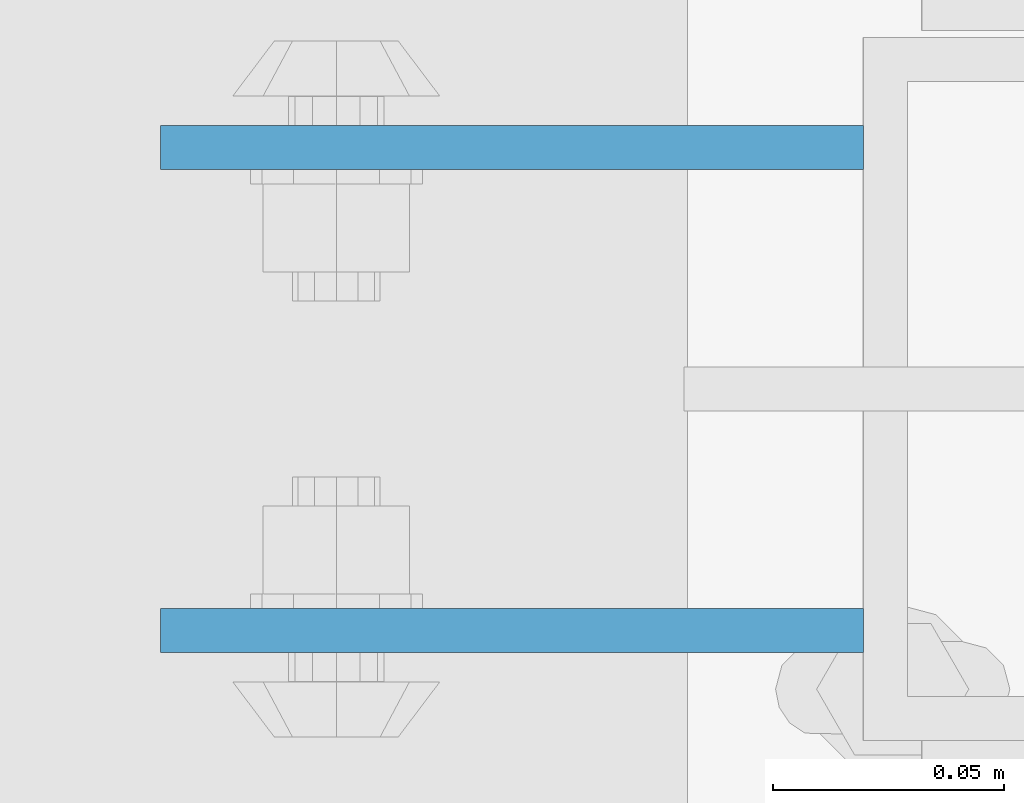
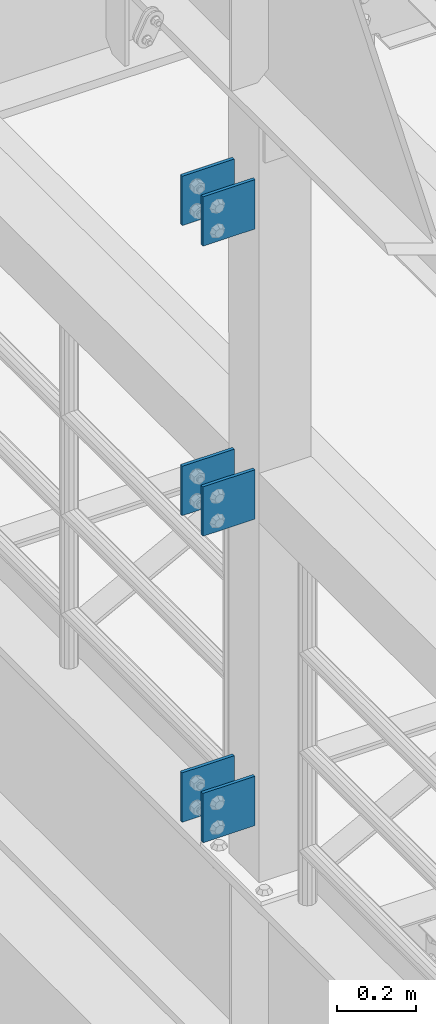
# One storey, part 1249 of 1876: 6 beams, 1 element without a shape of its own.
"""IFC2X3 building model written with IfcOpenShell, lengths in millimetres."""

from ifc_helpers import new_model, si_unit, frame, origin_with_axes, place, context, subcontext, project, spatial, faceted_brep, material, type_object, element, aggregate, save


model = new_model("IFC2X3")

# Units and contexts
model_context = context("Model", 3, precision=1e-05, world=origin_with_axes())
body_context = subcontext(model_context, "Body", "Model", "MODEL_VIEW")
ifc_project = project(units=[si_unit("LENGTHUNIT", "METRE", prefix="MILLI"), si_unit("AREAUNIT", "SQUARE_METRE"), si_unit("VOLUMEUNIT", "CUBIC_METRE"), si_unit("MASSUNIT", "GRAM", prefix="KILO"), si_unit("TIMEUNIT", "SECOND"), si_unit("PLANEANGLEUNIT", "RADIAN"), si_unit("SOLIDANGLEUNIT", "STERADIAN"), si_unit("THERMODYNAMICTEMPERATUREUNIT", "DEGREE_CELSIUS"), si_unit("LUMINOUSINTENSITYUNIT", "LUMEN")], contexts=[model_context])

# Site, building, storey
site_placement = place(None, origin_with_axes())
site = spatial("IfcSite", under=ifc_project, at=site_placement, CompositionType="ELEMENT")
building_placement = place(site_placement, origin_with_axes())
building = spatial("IfcBuilding", under=site, at=building_placement, Name="Undefined", CompositionType="ELEMENT")
storey_placement = place(building_placement, origin_with_axes())
storey = spatial("IfcBuildingStorey", under=building, at=storey_placement, Name="Undefined", CompositionType="ELEMENT", Elevation=0.0)

# Assembly, beams
assembly_placement = place(storey_placement, origin_with_axes())
assembly = element("IfcElementAssembly", 1, at=assembly_placement, inside=storey, Name="BEAM", AssemblyPlace="NOTDEFINED", PredefinedType="RIGID_FRAME")
ifc_material = material(Name="STEEL/A36")
beam_type = type_object("IfcBeamType", PredefinedType="NOTDEFINED")
beam_1_placement = place(assembly_placement, frame((-76.2, 3608.3875, 6330.95), z_axis=(0.0, 0.0, -1.0), x_axis=(-1.0, 0.0, 0.0)))
beam_1 = element("IfcBeam", 2, at=beam_1_placement, type_object=beam_type, material=ifc_material, Name="PLATE", context=body_context, shape_type="Brep", body=[
    faceted_brep([(0.0, 4.76249999999982, -76.1999999999998), (3.63797880709171e-12, 4.76249999999982, 76.1999969482422), (152.399993896484, 4.76250000000073, 76.1999969482422), (152.4, 4.76249999999982, -76.1999999999998), (3.63797880709171e-12, -4.76249999999982, 76.1999969482422), (152.399993896484, -4.76250000000073, 76.1999969482422), (0.0, -4.76249999999982, -76.1999999999998), (152.4, -4.76249999999982, -76.1999999999998)], [[[0, 1, 2, 3]], [[4, 5, 2, 1]], [[4, 6, 7, 5]], [[6, 0, 3, 7]], [[5, 7, 3, 2]], [[6, 4, 1, 0]]]),
])
beam_2_placement = place(assembly_placement, frame((-76.2, 3503.6125, 6330.95), z_axis=(0.0, 0.0, -1.0), x_axis=(-1.0, 0.0, 0.0)))
beam_2 = element("IfcBeam", 3, at=beam_2_placement, type_object=beam_type, material=ifc_material, Name="PLATE", context=body_context, shape_type="Brep", body=[
    faceted_brep([(0.0, 4.76249999999982, -76.1999999999998), (3.63797880709171e-12, 4.76249999999982, 76.1999969482422), (152.399993896484, 4.76250000000073, 76.1999969482422), (152.4, 4.76249999999982, -76.1999999999998), (3.63797880709171e-12, -4.76249999999982, 76.1999969482422), (152.399993896484, -4.76250000000073, 76.1999969482422), (0.0, -4.76249999999982, -76.1999999999998), (152.4, -4.76249999999982, -76.1999999999998)], [[[0, 1, 2, 3]], [[4, 5, 2, 1]], [[4, 6, 7, 5]], [[6, 0, 3, 7]], [[5, 7, 3, 2]], [[6, 4, 1, 0]]]),
])
beam_3_placement = place(assembly_placement, frame((-76.2, 3608.3875, 7226.3), z_axis=(0.0, 0.0, -1.0), x_axis=(-1.0, 0.0, 0.0)))
beam_3 = element("IfcBeam", 4, at=beam_3_placement, type_object=beam_type, material=ifc_material, Name="PLATE", context=body_context, shape_type="Brep", body=[
    faceted_brep([(0.0, 4.76249999999982, -76.1999999999998), (3.63797880709171e-12, 4.76249999999982, 76.1999969482422), (152.399993896484, 4.76250000000073, 76.1999969482422), (152.4, 4.76249999999982, -76.1999999999998), (3.63797880709171e-12, -4.76249999999982, 76.1999969482422), (152.399993896484, -4.76250000000073, 76.1999969482422), (0.0, -4.76249999999982, -76.1999999999998), (152.4, -4.76249999999982, -76.1999999999998)], [[[0, 1, 2, 3]], [[4, 5, 2, 1]], [[4, 6, 7, 5]], [[6, 0, 3, 7]], [[5, 7, 3, 2]], [[6, 4, 1, 0]]]),
])
beam_4_placement = place(assembly_placement, frame((-76.2, 3503.6125, 7226.3), z_axis=(0.0, 0.0, -1.0), x_axis=(-1.0, 0.0, 0.0)))
beam_4 = element("IfcBeam", 5, at=beam_4_placement, type_object=beam_type, material=ifc_material, Name="PLATE", context=body_context, shape_type="Brep", body=[
    faceted_brep([(0.0, 4.76249999999982, -76.1999999999998), (3.63797880709171e-12, 4.76249999999982, 76.1999969482422), (152.399993896484, 4.76250000000073, 76.1999969482422), (152.4, 4.76249999999982, -76.1999999999998), (3.63797880709171e-12, -4.76249999999982, 76.1999969482422), (152.399993896484, -4.76250000000073, 76.1999969482422), (0.0, -4.76249999999982, -76.1999999999998), (152.4, -4.76249999999982, -76.1999999999998)], [[[0, 1, 2, 3]], [[4, 5, 2, 1]], [[4, 6, 7, 5]], [[6, 0, 3, 7]], [[5, 7, 3, 2]], [[6, 4, 1, 0]]]),
])
beam_5_placement = place(assembly_placement, frame((-76.2, 3608.3875, 5384.8), z_axis=(0.0, 0.0, -1.0), x_axis=(-1.0, 0.0, 0.0)))
beam_5 = element("IfcBeam", 6, at=beam_5_placement, type_object=beam_type, material=ifc_material, Name="PLATE", context=body_context, shape_type="Brep", body=[
    faceted_brep([(0.0, 4.76249999999982, -76.1999999999998), (3.63797880709171e-12, 4.76249999999982, 76.1999969482422), (152.399993896484, 4.76250000000073, 76.1999969482422), (152.4, 4.76249999999982, -76.1999999999998), (3.63797880709171e-12, -4.76249999999982, 76.1999969482422), (152.399993896484, -4.76250000000073, 76.1999969482422), (0.0, -4.76249999999982, -76.1999999999998), (152.4, -4.76249999999982, -76.1999999999998)], [[[0, 1, 2, 3]], [[4, 5, 2, 1]], [[4, 6, 7, 5]], [[6, 0, 3, 7]], [[5, 7, 3, 2]], [[6, 4, 1, 0]]]),
])
beam_6_placement = place(assembly_placement, frame((-76.2, 3503.6125, 5384.8), z_axis=(0.0, 0.0, -1.0), x_axis=(-1.0, 0.0, 0.0)))
beam_6 = element("IfcBeam", 7, at=beam_6_placement, type_object=beam_type, material=ifc_material, Name="PLATE", context=body_context, shape_type="Brep", body=[
    faceted_brep([(0.0, 4.76249999999982, -76.1999999999998), (3.63797880709171e-12, 4.76249999999982, 76.1999969482422), (152.399993896484, 4.76250000000073, 76.1999969482422), (152.4, 4.76249999999982, -76.1999999999998), (3.63797880709171e-12, -4.76249999999982, 76.1999969482422), (152.399993896484, -4.76250000000073, 76.1999969482422), (0.0, -4.76249999999982, -76.1999999999998), (152.4, -4.76249999999982, -76.1999999999998)], [[[0, 1, 2, 3]], [[4, 5, 2, 1]], [[4, 6, 7, 5]], [[6, 0, 3, 7]], [[5, 7, 3, 2]], [[6, 4, 1, 0]]]),
])
aggregate(assembly, [beam_1, beam_2, beam_3, beam_4, beam_5, beam_6])

save(model, "model.ifc")
